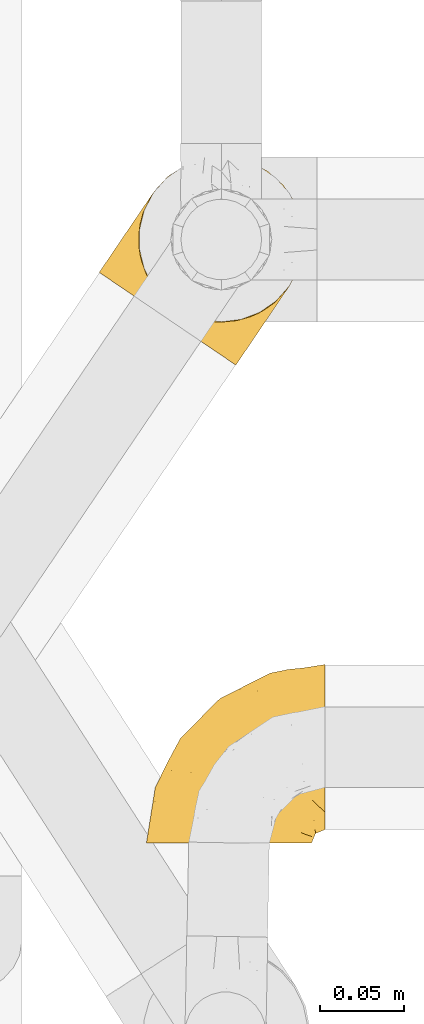
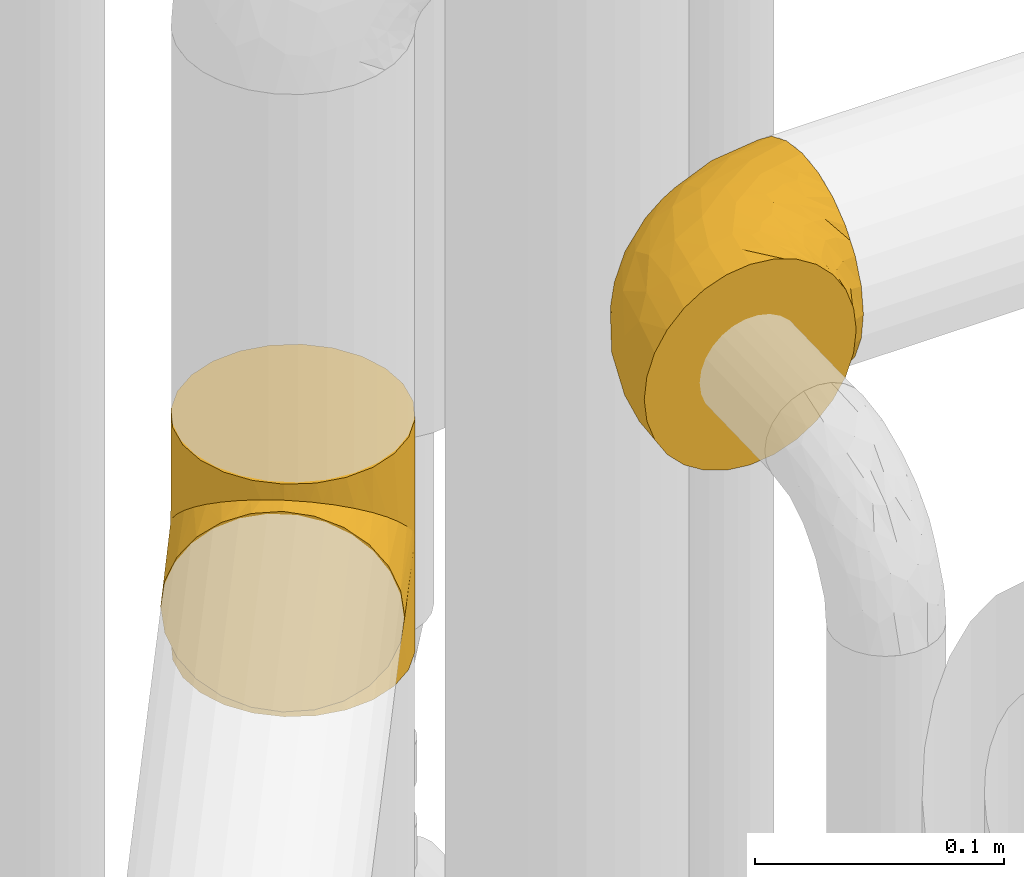
# One storey, part 384 of 827: 2 coverings.
"""IFC2X3 building model written with IfcOpenShell, lengths in millimetres."""

from ifc_helpers import new_model, entity, si_unit, converted_unit, derived_unit, direction, frame, origin, place, context, subcontext, project, spatial, faceted_brep, element, save


model = new_model("IFC2X3")

# Units and contexts
model_context = context("Model", 3, precision=0.01, world=origin(), true_north=direction((6.12303176911189e-17, 1.0)))
body_context = subcontext(model_context, "Body", "Model", "MODEL_VIEW")
ifc_project = project(units=[si_unit("LENGTHUNIT", "METRE", prefix="MILLI"), si_unit("AREAUNIT", "SQUARE_METRE"), si_unit("VOLUMEUNIT", "CUBIC_METRE"), converted_unit("PLANEANGLEUNIT", "DEGREE", entity("IfcRatioMeasure", 0.0174532925199433), si_unit("PLANEANGLEUNIT", "RADIAN"), dimensions=[0, 0, 0, 0, 0, 0, 0]), si_unit("MASSUNIT", "GRAM", prefix="KILO"), derived_unit("MASSDENSITYUNIT", [(si_unit("MASSUNIT", "GRAM", prefix="KILO"), 1), (si_unit("LENGTHUNIT", "METRE"), -3)]), derived_unit("MOMENTOFINERTIAUNIT", [(si_unit("LENGTHUNIT", "METRE"), 4)]), si_unit("TIMEUNIT", "SECOND"), si_unit("FREQUENCYUNIT", "HERTZ"), si_unit("THERMODYNAMICTEMPERATUREUNIT", "DEGREE_CELSIUS"), derived_unit("THERMALTRANSMITTANCEUNIT", [(si_unit("MASSUNIT", "GRAM", prefix="KILO"), 1), (si_unit("THERMODYNAMICTEMPERATUREUNIT", "KELVIN"), -1), (si_unit("TIMEUNIT", "SECOND"), -3)]), derived_unit("VOLUMETRICFLOWRATEUNIT", [(si_unit("LENGTHUNIT", "METRE"), 3), (si_unit("TIMEUNIT", "SECOND"), -1)]), derived_unit("MASSFLOWRATEUNIT", [(si_unit("MASSUNIT", "GRAM", prefix="KILO"), 1), (si_unit("TIMEUNIT", "SECOND"), -1)]), derived_unit("ROTATIONALFREQUENCYUNIT", [(si_unit("TIMEUNIT", "SECOND"), -1)]), si_unit("ELECTRICCURRENTUNIT", "AMPERE"), si_unit("ELECTRICVOLTAGEUNIT", "VOLT"), si_unit("POWERUNIT", "WATT"), si_unit("FORCEUNIT", "NEWTON", prefix="KILO"), si_unit("ILLUMINANCEUNIT", "LUX"), si_unit("LUMINOUSFLUXUNIT", "LUMEN"), si_unit("LUMINOUSINTENSITYUNIT", "CANDELA"), derived_unit("USERDEFINED", [(si_unit("MASSUNIT", "GRAM", prefix="KILO"), -1), (si_unit("LENGTHUNIT", "METRE"), -2), (si_unit("TIMEUNIT", "SECOND"), 3), (si_unit("LUMINOUSFLUXUNIT", "LUMEN"), 1)]), derived_unit("LINEARVELOCITYUNIT", [(si_unit("LENGTHUNIT", "METRE"), 1), (si_unit("TIMEUNIT", "SECOND"), -1)]), si_unit("PRESSUREUNIT", "PASCAL"), derived_unit("USERDEFINED", [(si_unit("LENGTHUNIT", "METRE"), -2), (si_unit("MASSUNIT", "GRAM", prefix="KILO"), 1), (si_unit("TIMEUNIT", "SECOND"), -2)]), derived_unit("LINEARFORCEUNIT", [(si_unit("MASSUNIT", "GRAM", prefix="KILO"), 1), (si_unit("LENGTHUNIT", "METRE"), 1), (si_unit("TIMEUNIT", "SECOND"), -2), (si_unit("LENGTHUNIT", "METRE"), -1)]), derived_unit("PLANARFORCEUNIT", [(si_unit("MASSUNIT", "GRAM", prefix="KILO"), 1), (si_unit("LENGTHUNIT", "METRE"), 1), (si_unit("TIMEUNIT", "SECOND"), -2), (si_unit("LENGTHUNIT", "METRE"), -2)])], contexts=[model_context])

# Site, building, storey
site_placement = place(None, origin())
site = spatial("IfcSite", under=ifc_project, at=site_placement, CompositionType="ELEMENT")
building_placement = place(site_placement, origin())
building = spatial("IfcBuilding", under=site, at=building_placement, CompositionType="ELEMENT")
storey_placement = place(building_placement, frame((0.0, 0.0, 28200.0)))
storey = spatial("IfcBuildingStorey", under=building, at=storey_placement, Name="08", CompositionType="ELEMENT", Elevation=28200.0)

# Coverings
covering_1_placement = place(storey_placement, frame((46949.92, 13874.91, 2546.71)))
element("IfcCovering", 1, at=covering_1_placement, inside=storey, Name=":ADSK_", ObjectType=":ADSK_", PredefinedType="INSULATION", context=body_context, shape_type="Brep", body=[
    faceted_brep([(50.75, 1.6, 99.9), (39.8, 1.6, 98.66), (29.41, 1.6, 95.02), (20.09, 1.6, 89.17), (12.31, 1.6, 81.38), (6.46, 1.6, 72.06), (2.83, 1.6, 61.68), (1.6, 1.6, 50.75), (2.83, 1.6, 39.8), (6.47, 1.6, 29.41), (12.32, 1.6, 20.09), (20.11, 1.6, 12.31), (29.43, 1.6, 6.46), (39.81, 1.6, 2.83), (50.75, 1.6, 1.6), (56.45, 1.6, 2.24), (61.69, 1.6, 2.83), (66.88, 1.6, 4.65), (72.08, 1.6, 6.47), (81.4, 1.6, 12.32), (89.18, 1.6, 20.11), (95.03, 1.6, 29.43), (98.66, 1.6, 39.81), (99.9, 1.6, 50.75), (98.66, 1.6, 61.69), (95.02, 1.6, 72.08), (89.17, 1.6, 81.4), (81.38, 1.6, 89.18), (72.06, 1.6, 95.03), (66.87, 1.6, 96.85), (61.68, 1.6, 98.66), (56.45, 1.6, 99.25), (53.6, 1.6, 99.57), (107.75, 11.12, 38.02), (107.75, 16.03, 26.17), (107.75, 19.94, 21.08), (107.75, 23.84, 15.99), (107.75, 28.93, 12.09), (107.75, 34.02, 8.18), (107.75, 39.95, 5.73), (107.75, 45.87, 3.27), (107.75, 52.86, 2.35), (107.75, 55.73, 1.97), (107.75, 58.6, 1.6), (107.75, 71.32, 3.27), (107.75, 83.17, 8.18), (107.75, 93.35, 15.99), (107.75, 101.16, 26.17), (107.75, 106.07, 38.02), (107.75, 107.75, 50.75), (107.75, 106.07, 63.47), (107.75, 101.16, 75.32), (107.75, 93.35, 85.5), (107.75, 83.17, 93.31), (107.75, 71.32, 98.22), (107.75, 58.6, 99.9), (107.75, 52.86, 99.14), (107.75, 45.87, 98.22), (107.75, 39.95, 95.77), (107.75, 34.02, 93.31), (107.75, 28.93, 89.4), (107.75, 23.84, 85.5), (107.75, 19.94, 80.41), (107.75, 16.03, 75.32), (107.75, 11.12, 63.47), (107.75, 9.45, 50.75), (39.38, 81.82, 59.31), (49.75, 84.02, 73.08), (57.38, 93.05, 63.72), (74.94, 102.55, 50.75), (85.97, 104.83, 58.64), (95.66, 105.83, 50.75), (67.82, 91.87, 76.74), (83.09, 101.74, 67.68), (89.16, 97.07, 78.92), (37.01, 38.45, 94.31), (43.46, 22.17, 98.76), (51.79, 42.04, 98.4), (85.58, 77.69, 94.57), (62.84, 75.76, 89.91), (62.77, 62.11, 96.32), (88.17, 66.08, 98.79), (85.93, 54.26, 99.9), (91.42, 55.35, 99.9), (96.91, 56.44, 99.9), (99.62, 56.98, 99.9), (102.33, 57.52, 99.9), (82.57, 87.84, 87.31), (32.75, 19.41, 95.61), (13.79, 48.89, 60.43), (6.77, 26.34, 65.24), (16.46, 44.55, 72.87), (55.08, 23.41, 99.9), (58.17, 28.03, 99.9), (61.26, 32.65, 99.9), (64.35, 37.28, 99.9), (67.44, 41.9, 99.9), (24.18, 20.6, 90.65), (23.37, 63.36, 63.14), (49.76, 62.21, 91.89), (9.84, 19.94, 75.25), (3.51, 13.68, 50.75), (55.75, 80.85, 82.18), (42.34, 66.53, 85.08), (37.78, 71.06, 76.93), (21.87, 63.99, 50.75), (33.61, 75.73, 50.75), (17.1, 26.77, 83.02), (51.28, 4.31, 99.9), (51.82, 7.01, 99.9), (52.9, 12.43, 99.9), (53.99, 17.92, 99.9), (28.01, 43.43, 87.13), (28.99, 56.23, 80.85), (69.9, 54.97, 99.17), (6.79, 34.4, 50.75), (72.06, 44.99, 99.9), (76.69, 48.08, 99.9), (81.31, 51.17, 99.9), (45.35, 87.47, 50.75), (34.79, 74.55, 67.61), (25.72, 60.86, 72.25), (14.33, 49.19, 50.75), (60.15, 95.01, 50.75), (62.38, 10.27, 98.69), (100.57, 48.79, 99.01), (91.06, 45.16, 98.79), (97.66, 44.99, 98.29), (97.55, 6.17, 68.51), (93.65, 7.65, 76.82), (66.85, 21.59, 98.54), (61.93, 19.96, 99.3), (101.4, 21.0, 83.57), (100.07, 27.2, 89.47), (101.36, 14.83, 75.76), (95.94, 19.7, 84.86), (96.3, 10.93, 75.89), (101.98, 9.63, 64.77), (85.88, 19.97, 90.83), (78.88, 21.13, 94.62), (82.8, 14.14, 90.37), (102.58, 30.2, 91.18), (82.88, 8.12, 88.65), (88.57, 9.93, 84.11), (88.67, 24.62, 91.75), (69.08, 11.87, 96.86), (102.19, 7.15, 50.75), (100.06, 5.32, 58.97), (70.56, 26.68, 98.37), (91.07, 13.92, 83.91), (77.56, 30.67, 97.52), (96.59, 36.65, 95.55), (86.38, 42.89, 98.76), (91.79, 34.04, 95.26), (81.71, 36.6, 98.04), (94.11, 26.41, 90.65), (76.09, 10.07, 93.51), (76.91, 15.83, 94.16), (81.44, 41.99, 99.1), (101.37, 14.83, 25.73), (94.12, 26.4, 10.84), (101.41, 21.01, 17.92), (95.96, 19.71, 16.64), (96.22, 5.72, 30.44), (66.85, 21.6, 2.95), (61.94, 19.96, 2.19), (58.17, 28.03, 1.6), (69.1, 11.87, 4.63), (88.58, 9.93, 17.39), (96.91, 56.44, 1.6), (102.33, 57.52, 1.6), (105.04, 58.06, 1.6), (82.9, 8.13, 12.86), (82.82, 14.15, 11.13), (97.66, 44.99, 3.2), (96.59, 36.65, 5.94), (100.07, 27.21, 12.02), (91.79, 34.04, 6.23), (102.58, 30.2, 10.31), (76.13, 10.06, 8.0), (76.93, 15.83, 7.34), (100.57, 48.79, 2.48), (86.38, 42.89, 2.73), (90.86, 45.38, 2.64), (52.9, 12.43, 1.6), (62.39, 10.28, 2.8), (101.98, 9.64, 36.71), (91.42, 55.35, 1.6), (85.93, 54.26, 1.6), (99.49, 6.05, 38.59), (51.82, 7.01, 1.6), (52.36, 9.72, 1.6), (61.26, 32.65, 1.6), (70.56, 26.68, 3.12), (91.09, 13.92, 17.59), (64.35, 37.28, 1.6), (77.6, 30.66, 3.98), (78.89, 21.14, 6.87), (81.71, 36.59, 3.45), (88.69, 24.6, 9.76), (53.99, 17.92, 1.6), (55.08, 23.41, 1.6), (96.31, 10.93, 25.62), (85.9, 19.97, 10.67), (81.45, 41.99, 2.39), (76.69, 48.08, 1.6), (81.31, 51.17, 1.6), (72.06, 44.99, 1.6), (67.44, 41.9, 1.6), (69.6, 55.26, 2.4), (85.97, 104.83, 42.85), (82.57, 87.84, 14.18), (63.16, 75.91, 11.56), (55.81, 80.84, 19.27), (67.81, 91.87, 24.75), (49.73, 83.98, 28.37), (32.55, 19.16, 5.95), (43.23, 22.37, 2.79), (88.17, 66.08, 2.71), (57.38, 93.05, 37.78), (83.08, 101.74, 33.81), (89.16, 97.07, 22.57), (85.58, 77.69, 6.92), (16.46, 44.55, 28.61), (6.77, 26.34, 36.24), (13.8, 48.9, 41.05), (37.71, 70.99, 24.55), (34.8, 74.55, 33.88), (36.83, 37.8, 7.11), (39.38, 81.82, 42.18), (17.12, 26.77, 18.46), (24.19, 20.6, 10.84), (28.89, 56.15, 20.69), (25.69, 60.85, 29.27), (51.77, 42.06, 3.1), (45.66, 57.03, 9.18), (23.39, 63.4, 38.38), (9.85, 19.94, 26.23), (28.11, 43.59, 14.34), (62.27, 62.61, 5.46), (42.35, 66.52, 16.39)], [[[0, 1, 2, 3, 4, 5, 6, 7, 8, 9, 10, 11, 12, 13, 14, 15, 16, 17, 18, 19, 20, 21, 22, 23, 24, 25, 26, 27, 28, 29, 30, 31, 32]], [[33, 34, 35, 36, 37, 38, 39, 40, 41, 42, 43, 44, 45, 46, 47, 48, 49, 50, 51, 52, 53, 54, 55, 56, 57, 58, 59, 60, 61, 62, 63, 64, 65]], [[66, 67, 68]], [[69, 70, 71]], [[68, 72, 73]], [[73, 72, 74]], [[75, 76, 77]], [[78, 79, 80]], [[51, 50, 73]], [[81, 82, 83, 84, 85, 86, 55]], [[52, 87, 53]], [[74, 52, 51]], [[2, 1, 88]], [[89, 90, 91]], [[77, 92, 93, 94, 95, 96]], [[55, 54, 81]], [[78, 53, 87]], [[5, 90, 6]], [[88, 76, 75]], [[97, 3, 2]], [[89, 91, 98]], [[99, 80, 79]], [[90, 5, 100]], [[74, 87, 52]], [[100, 5, 4]], [[90, 101, 6]], [[79, 102, 103]], [[102, 67, 104]], [[105, 98, 106]], [[107, 4, 3]], [[76, 0, 108, 109, 110, 111, 92]], [[107, 112, 113]], [[114, 77, 96]], [[89, 115, 90]], [[114, 96, 116, 117, 118, 82]], [[75, 97, 88]], [[119, 66, 68]], [[50, 71, 70]], [[100, 91, 90]], [[99, 77, 80]], [[102, 104, 103]], [[97, 107, 3]], [[80, 81, 78]], [[107, 97, 112]], [[68, 73, 70]], [[66, 98, 120]], [[78, 81, 54]], [[114, 81, 80]], [[53, 78, 54]], [[78, 87, 79]], [[102, 87, 72]], [[79, 103, 99]], [[4, 107, 100]], [[91, 100, 107]], [[88, 97, 2]], [[112, 97, 75]], [[99, 112, 75]], [[103, 104, 113]], [[91, 121, 98]], [[89, 105, 122, 115]], [[101, 90, 115]], [[101, 7, 6]], [[88, 1, 76]], [[0, 76, 1]], [[92, 77, 76]], [[73, 74, 51]], [[87, 74, 72]], [[81, 114, 82]], [[77, 114, 80]], [[87, 102, 79]], [[67, 102, 72]], [[68, 67, 72]], [[67, 120, 104]], [[120, 121, 104]], [[104, 121, 113]], [[121, 120, 98]], [[91, 107, 113]], [[91, 113, 121]], [[103, 113, 112]], [[106, 98, 66]], [[105, 89, 98]], [[106, 66, 119]], [[67, 66, 120]], [[68, 69, 123, 119]], [[50, 49, 71]], [[50, 70, 73]], [[112, 99, 103]], [[77, 99, 75]], [[69, 68, 70]], [[29, 124, 110]], [[84, 83, 125]], [[126, 82, 118]], [[59, 58, 127]], [[25, 128, 129]], [[130, 93, 131]], [[132, 62, 133]], [[134, 135, 136]], [[137, 65, 64]], [[64, 134, 137]], [[138, 139, 140]], [[111, 110, 124, 92]], [[134, 136, 137]], [[134, 64, 63]], [[141, 61, 60]], [[125, 58, 57]], [[142, 143, 140]], [[142, 26, 143]], [[127, 83, 82]], [[28, 124, 29]], [[108, 0, 32, 31, 30, 110, 109]], [[30, 29, 110]], [[135, 144, 138]], [[28, 145, 124]], [[57, 56, 55, 86, 85, 84]], [[146, 147, 23]], [[24, 23, 147]], [[25, 143, 26]], [[95, 94, 148]], [[24, 128, 25]], [[149, 138, 143]], [[124, 145, 131]], [[127, 58, 125]], [[150, 148, 139]], [[127, 126, 151]], [[151, 59, 127]], [[152, 151, 126]], [[153, 154, 155]], [[153, 133, 141]], [[145, 28, 27]], [[142, 156, 27]], [[157, 148, 130]], [[61, 133, 62]], [[134, 132, 135]], [[147, 128, 24]], [[65, 137, 146]], [[146, 137, 147]], [[128, 137, 136]], [[137, 128, 147]], [[128, 136, 129]], [[149, 129, 136]], [[25, 129, 143]], [[158, 152, 117]], [[152, 118, 117]], [[153, 151, 152]], [[158, 116, 154]], [[144, 150, 138]], [[153, 152, 158]], [[133, 153, 155]], [[133, 155, 132]], [[60, 151, 141]], [[135, 132, 155]], [[134, 63, 132]], [[144, 135, 155]], [[135, 138, 149]], [[155, 154, 144]], [[150, 154, 96]], [[154, 150, 144]], [[148, 94, 130]], [[82, 126, 127]], [[118, 152, 126]], [[150, 96, 95]], [[139, 148, 157]], [[150, 95, 148]], [[93, 92, 131]], [[130, 145, 156]], [[130, 94, 93]], [[84, 125, 57]], [[127, 125, 83]], [[140, 139, 157]], [[150, 139, 138]], [[140, 157, 142]], [[138, 140, 143]], [[156, 142, 157]], [[27, 26, 142]], [[130, 156, 157]], [[145, 27, 156]], [[132, 63, 62]], [[124, 131, 92]], [[130, 131, 145]], [[129, 149, 143]], [[135, 149, 136]], [[141, 133, 61]], [[60, 59, 151]], [[141, 151, 153]], [[116, 96, 154]], [[153, 158, 154]], [[158, 117, 116]], [[34, 33, 159]], [[160, 161, 162]], [[22, 21, 163]], [[164, 165, 166]], [[19, 18, 167]], [[168, 21, 20]], [[42, 41, 40, 169, 170, 171, 43]], [[172, 173, 168]], [[174, 38, 175]], [[176, 177, 178]], [[179, 164, 180]], [[40, 181, 169]], [[182, 183, 175]], [[17, 184, 185]], [[65, 146, 186]], [[187, 174, 188]], [[23, 22, 189]], [[174, 39, 38]], [[15, 14, 190, 191, 184, 16]], [[181, 40, 39]], [[192, 193, 164]], [[194, 163, 168]], [[33, 186, 159]], [[180, 173, 172]], [[195, 196, 193]], [[18, 185, 167]], [[173, 180, 197]], [[198, 199, 196]], [[200, 201, 185, 184]], [[184, 17, 16]], [[18, 17, 185]], [[202, 159, 186]], [[194, 168, 203]], [[189, 163, 202]], [[204, 205, 182]], [[187, 181, 174]], [[160, 177, 176]], [[206, 183, 182]], [[206, 182, 205]], [[201, 165, 185]], [[165, 164, 167]], [[172, 179, 180]], [[202, 194, 162]], [[176, 161, 160]], [[65, 186, 33]], [[163, 189, 22]], [[175, 177, 182]], [[174, 183, 188]], [[177, 198, 204]], [[199, 160, 162]], [[198, 207, 204]], [[175, 38, 37]], [[198, 177, 160]], [[178, 177, 175]], [[176, 35, 161]], [[34, 159, 161]], [[162, 161, 159]], [[202, 162, 159]], [[199, 162, 203]], [[196, 199, 203]], [[198, 160, 199]], [[193, 197, 180]], [[208, 198, 196]], [[188, 183, 206]], [[175, 183, 174]], [[193, 192, 195]], [[195, 208, 196]], [[197, 196, 203]], [[180, 164, 193]], [[168, 163, 21]], [[166, 165, 201]], [[166, 192, 164]], [[189, 202, 186]], [[186, 146, 189]], [[23, 189, 146]], [[174, 181, 39]], [[169, 181, 187]], [[196, 197, 193]], [[173, 203, 168]], [[203, 173, 197]], [[172, 168, 20]], [[20, 19, 172]], [[179, 172, 19]], [[19, 167, 179]], [[164, 179, 167]], [[35, 176, 36]], [[35, 34, 161]], [[185, 165, 167]], [[162, 194, 203]], [[163, 194, 202]], [[176, 178, 36]], [[37, 36, 178]], [[175, 37, 178]], [[177, 204, 182]], [[207, 198, 208]], [[207, 205, 204]], [[209, 188, 206, 205, 207, 208]], [[48, 210, 71]], [[211, 212, 213]], [[214, 213, 215]], [[216, 217, 13]], [[218, 43, 171, 170, 169, 187, 188]], [[219, 220, 214]], [[47, 46, 221]], [[210, 48, 220]], [[211, 222, 212]], [[222, 45, 44]], [[221, 220, 47]], [[47, 220, 48]], [[221, 211, 214]], [[223, 224, 225]], [[211, 46, 45]], [[226, 227, 215]], [[43, 218, 44]], [[217, 216, 228]], [[219, 215, 229]], [[14, 13, 217]], [[224, 9, 8]], [[10, 230, 11]], [[11, 231, 12]], [[232, 223, 233]], [[234, 208, 195, 192, 166, 201]], [[235, 234, 228]], [[222, 44, 218]], [[106, 229, 236]], [[224, 237, 9]], [[231, 238, 228]], [[9, 237, 10]], [[115, 224, 101]], [[239, 234, 235]], [[231, 11, 230]], [[223, 230, 237]], [[224, 8, 101]], [[223, 236, 233]], [[225, 115, 122, 105]], [[216, 12, 231]], [[209, 234, 239]], [[210, 219, 69]], [[219, 214, 215]], [[229, 119, 219]], [[209, 218, 188]], [[239, 212, 222]], [[239, 222, 218]], [[45, 222, 211]], [[235, 212, 239]], [[213, 212, 240]], [[223, 237, 224]], [[230, 10, 237]], [[238, 231, 230]], [[216, 231, 228]], [[232, 230, 223]], [[235, 238, 240]], [[115, 225, 224]], [[233, 236, 227]], [[8, 7, 101]], [[234, 209, 208]], [[218, 209, 239]], [[217, 228, 234]], [[13, 12, 216]], [[234, 201, 217]], [[217, 201, 200, 184, 191, 190, 14]], [[211, 221, 46]], [[220, 221, 214]], [[71, 210, 69]], [[71, 49, 48]], [[219, 210, 220]], [[226, 215, 213]], [[211, 213, 214]], [[226, 213, 240]], [[215, 227, 229]], [[232, 240, 238]], [[233, 227, 226]], [[232, 233, 226]], [[236, 223, 225]], [[240, 232, 226]], [[232, 238, 230]], [[225, 105, 236]], [[236, 105, 106]], [[236, 229, 227]], [[123, 69, 219, 119]], [[106, 119, 229]], [[238, 235, 228]], [[212, 235, 240]]]),
])
covering_2_placement = place(storey_placement, frame((46921.77, 14159.32, 2243.0)))
element("IfcCovering", 2, at=covering_2_placement, inside=storey, Name=":ADSK_", ObjectType=":ADSK_", PredefinedType="INSULATION", context=body_context, shape_type="Brep", body=[
    faceted_brep([(30.24, 98.21, 50.38), (33.59, 103.94, 0.0), (27.83, 92.47, 0.0), (25.24, 79.91, 0.0), (25.96, 85.43, 37.4), (25.39, 71.18, 25.28), (26.0, 67.1, 0.0), (25.16, 78.46, 31.18), (33.59, 103.94, 57.0), (30.24, 98.21, 63.62), (33.59, 103.94, 114.0), (43.08, 38.65, 8.29), (41.89, 39.94, 0.0), (44.28, 37.81, 0.0), (27.68, 92.03, 43.83), (46.68, 35.68, 7.85), (46.68, 35.68, 0.0), (44.28, 37.81, 114.0), (46.68, 35.68, 106.15), (46.68, 35.68, 114.0), (26.78, 63.66, 19.84), (30.04, 54.92, 0.0), (33.56, 49.56, 0.0), (37.09, 44.2, 0.0), (36.6, 45.11, 10.0), (39.48, 41.63, 8.74), (29.51, 56.04, 15.07), (33.72, 48.58, 11.25), (39.49, 42.07, 0.0), (49.55, 34.24, 0.0), (52.41, 32.8, 0.0), (51.25, 33.24, 8.4), (55.81, 30.8, 8.94), (55.28, 31.36, 0.0), (58.15, 29.92, 0.0), (65.37, 28.02, 12.0), (64.43, 28.63, 0.0), (70.71, 27.34, 0.0), (60.59, 29.41, 10.47), (74.7, 27.21, 16.57), (77.12, 27.71, 0.0), (83.44, 28.07, 22.18), (70.04, 27.61, 14.29), (48.96, 34.46, 8.12), (83.52, 28.09, 0.0), (91.42, 30.3, 28.5), (95.7, 32.13, 0.0), (98.58, 33.64, 35.29), (106.42, 39.18, 0.0), (110.36, 43.0, 49.65), (114.94, 48.77, 0.0), (48.96, 34.46, 105.88), (104.9, 37.92, 42.38), (114.94, 48.77, 57.0), (110.36, 43.0, 64.35), (114.94, 48.77, 114.0), (118.49, 97.79, 114.0), (111.44, 108.51, 114.0), (101.85, 117.04, 114.0), (90.38, 122.79, 114.0), (77.82, 125.38, 114.0), (65.01, 124.63, 114.0), (52.83, 120.59, 114.0), (42.11, 113.53, 114.0), (27.83, 92.47, 114.0), (25.24, 79.91, 114.0), (26.0, 67.1, 114.0), (30.04, 54.92, 114.0), (33.56, 49.56, 114.0), (37.09, 44.2, 114.0), (39.49, 42.07, 114.0), (41.89, 39.94, 114.0), (49.55, 34.24, 114.0), (52.41, 32.8, 114.0), (55.28, 31.36, 114.0), (58.15, 29.92, 114.0), (64.43, 28.63, 114.0), (70.71, 27.34, 114.0), (77.12, 27.71, 114.0), (83.52, 28.09, 114.0), (95.7, 32.13, 114.0), (106.42, 39.18, 114.0), (120.7, 60.24, 114.0), (123.29, 72.81, 114.0), (122.54, 85.61, 114.0), (42.11, 113.53, 0.0), (52.83, 120.59, 0.0), (65.01, 124.63, 0.0), (77.82, 125.38, 0.0), (90.38, 122.79, 0.0), (101.85, 117.04, 0.0), (111.44, 108.51, 0.0), (118.49, 97.79, 0.0), (122.54, 85.61, 0.0), (123.29, 72.81, 0.0), (120.7, 60.24, 0.0), (27.68, 92.03, 70.17), (25.96, 85.43, 76.6), (43.08, 38.65, 105.71), (25.16, 78.46, 82.82), (25.39, 71.18, 88.72), (39.48, 41.63, 105.26), (26.78, 63.66, 94.16), (29.51, 56.04, 98.93), (36.6, 45.11, 104.0), (33.72, 48.58, 102.75), (65.37, 28.02, 102.0), (60.59, 29.41, 103.53), (74.7, 27.21, 97.43), (55.81, 30.8, 105.06), (83.44, 28.07, 91.82), (70.04, 27.61, 99.71), (51.25, 33.24, 105.6), (98.58, 33.64, 78.71), (104.9, 37.92, 71.62), (91.42, 30.3, 85.5), (2.98, 55.83, 44.28), (7.05, 53.07, 32.42), (13.51, 48.69, 22.25), (21.93, 42.97, 14.43), (26.84, 39.65, 11.98), (31.75, 36.32, 9.52), (34.38, 34.54, 9.11), (37.01, 32.75, 8.69), (39.64, 30.97, 8.27), (42.27, 29.18, 7.85), (44.91, 27.4, 8.27), (47.54, 25.61, 8.69), (50.17, 23.83, 9.11), (52.8, 22.04, 9.52), (57.71, 18.71, 11.98), (62.61, 15.39, 14.43), (66.83, 12.53, 18.34), (71.04, 9.67, 22.25), (77.5, 5.29, 32.42), (81.57, 2.54, 44.28), (82.95, 1.6, 57.0), (81.57, 2.54, 69.72), (77.5, 5.29, 81.57), (71.04, 9.67, 91.75), (66.83, 12.53, 95.66), (62.61, 15.39, 99.57), (57.71, 18.71, 102.02), (52.8, 22.04, 104.48), (50.17, 23.83, 104.89), (47.54, 25.61, 105.31), (44.91, 27.4, 105.73), (42.27, 29.18, 106.15), (39.64, 30.97, 105.73), (37.01, 32.75, 105.31), (34.38, 34.54, 104.89), (31.75, 36.32, 104.48), (26.84, 39.65, 102.02), (21.93, 42.97, 99.57), (13.51, 48.69, 91.75), (7.05, 53.07, 81.57), (2.98, 55.83, 69.72), (1.6, 56.77, 57.0)], [[[0, 1, 2]], [[2, 3, 4]], [[5, 3, 6]], [[5, 7, 3]], [[0, 8, 1]], [[8, 9, 10]], [[11, 12, 13]], [[4, 14, 2]], [[7, 4, 3]], [[0, 2, 14]], [[15, 13, 16]], [[17, 18, 19]], [[20, 6, 21]], [[22, 23, 24]], [[15, 11, 13]], [[23, 25, 24]], [[26, 20, 21]], [[27, 21, 22]], [[27, 22, 24]], [[25, 12, 11]], [[25, 23, 28, 12]], [[26, 21, 27]], [[6, 20, 5]], [[29, 30, 31]], [[32, 30, 33, 34]], [[35, 36, 37]], [[38, 36, 35]], [[38, 32, 34]], [[39, 37, 40]], [[41, 39, 40]], [[35, 37, 39, 42]], [[43, 16, 29]], [[40, 44, 41]], [[45, 44, 46]], [[47, 46, 48]], [[49, 48, 50]], [[47, 45, 46]], [[16, 43, 15]], [[51, 19, 18]], [[49, 52, 48]], [[53, 49, 50]], [[54, 53, 55]], [[30, 32, 31]], [[47, 48, 52]], [[36, 38, 34]], [[44, 45, 41]], [[29, 31, 43]], [[56, 57, 58, 59, 60, 61, 62, 63, 10, 64, 65, 66, 67, 68, 69, 70, 71, 17, 19, 72, 73, 74, 75, 76, 77, 78, 79, 80, 81, 55, 82, 83, 84]], [[85, 86, 87, 88, 89, 90, 91, 92, 93, 94, 95, 50, 48, 46, 44, 40, 37, 36, 34, 33, 30, 29, 16, 13, 12, 28, 23, 22, 21, 6, 3, 2, 1]], [[88, 87, 61, 60]], [[58, 90, 89, 59]], [[89, 88, 60, 59]], [[62, 86, 85, 63]], [[1, 8, 10, 63, 85]], [[61, 87, 86, 62]], [[96, 97, 64]], [[18, 17, 98]], [[9, 96, 64]], [[10, 9, 64]], [[65, 99, 100]], [[65, 64, 97]], [[71, 101, 98]], [[65, 100, 66]], [[99, 65, 97]], [[102, 103, 67]], [[104, 68, 105]], [[104, 101, 69]], [[68, 104, 69]], [[103, 105, 67]], [[66, 102, 67]], [[101, 71, 70, 69]], [[68, 67, 105]], [[98, 17, 71]], [[102, 66, 100]], [[106, 76, 107]], [[106, 77, 76]], [[77, 108, 78]], [[109, 75, 74, 73]], [[110, 78, 108]], [[111, 108, 77, 106]], [[19, 51, 72]], [[109, 73, 112]], [[72, 51, 112]], [[76, 75, 107]], [[110, 79, 78]], [[75, 109, 107]], [[113, 114, 81]], [[114, 54, 81]], [[79, 115, 80]], [[115, 79, 110]], [[113, 80, 115]], [[113, 81, 80]], [[54, 55, 81]], [[112, 73, 72]], [[53, 50, 95, 82, 55]], [[82, 95, 94, 83]], [[94, 93, 84, 83]], [[84, 93, 92, 56]], [[56, 92, 91, 57]], [[57, 91, 90, 58]], [[116, 117, 118, 119, 120, 121, 122, 123, 124, 125, 126, 127, 128, 129, 130, 131, 132, 133, 134, 135, 136, 137, 138, 139, 140, 141, 142, 143, 144, 145, 146, 147, 148, 149, 150, 151, 152, 153, 154, 155, 156, 157]], [[25, 123, 122, 121]], [[119, 118, 20]], [[15, 124, 11]], [[27, 120, 119]], [[124, 15, 125]], [[124, 123, 11]], [[120, 24, 121]], [[26, 27, 119]], [[20, 26, 119]], [[24, 120, 27]], [[25, 121, 24]], [[118, 5, 20]], [[7, 5, 117]], [[117, 5, 118]], [[4, 117, 116]], [[0, 116, 157]], [[4, 7, 117]], [[0, 14, 116]], [[8, 0, 157]], [[4, 116, 14]], [[123, 25, 11]], [[9, 157, 156]], [[156, 155, 97]], [[100, 155, 154]], [[100, 99, 155]], [[9, 8, 157]], [[98, 149, 148]], [[97, 96, 156]], [[99, 97, 155]], [[9, 156, 96]], [[18, 148, 147]], [[102, 154, 153]], [[152, 151, 104]], [[18, 98, 148]], [[151, 101, 104]], [[103, 102, 153]], [[105, 153, 152]], [[105, 152, 104]], [[101, 149, 98]], [[101, 151, 150, 149]], [[103, 153, 105]], [[154, 102, 100]], [[146, 145, 112]], [[109, 145, 144, 143]], [[106, 142, 141]], [[107, 142, 106]], [[107, 109, 143]], [[108, 141, 140]], [[110, 108, 140]], [[106, 141, 108, 111]], [[51, 147, 146]], [[140, 139, 110]], [[115, 139, 138]], [[113, 138, 137]], [[54, 137, 136]], [[113, 115, 138]], [[147, 51, 18]], [[54, 114, 137]], [[53, 54, 136]], [[145, 109, 112]], [[113, 137, 114]], [[142, 107, 143]], [[139, 115, 110]], [[146, 112, 51]], [[49, 136, 135]], [[135, 134, 47]], [[45, 134, 133]], [[45, 47, 134]], [[43, 125, 15]], [[49, 53, 136]], [[32, 129, 128, 127]], [[47, 52, 135]], [[49, 135, 52]], [[31, 127, 126]], [[131, 35, 42, 39]], [[125, 43, 126]], [[39, 132, 131]], [[130, 129, 38]], [[43, 31, 126]], [[41, 133, 132]], [[41, 132, 39]], [[35, 130, 38]], [[32, 127, 31]], [[35, 131, 130]], [[129, 32, 38]], [[133, 41, 45]]]),
])

save(model, "model.ifc")
